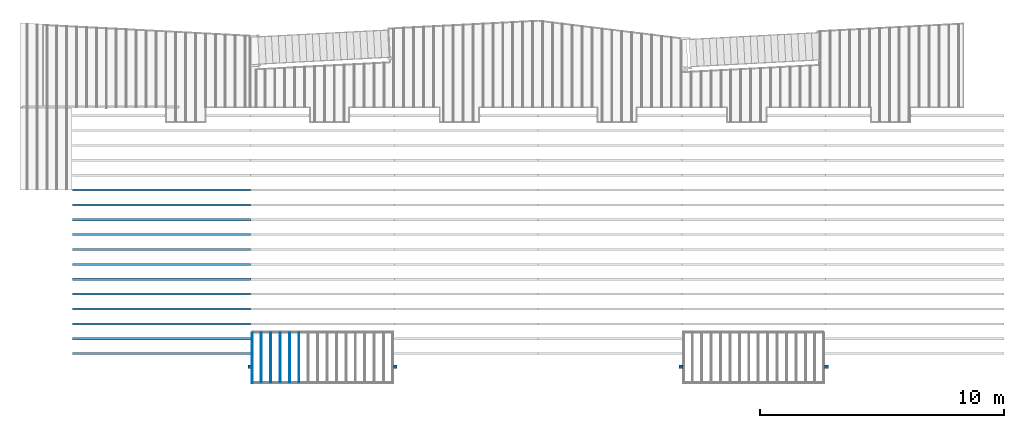
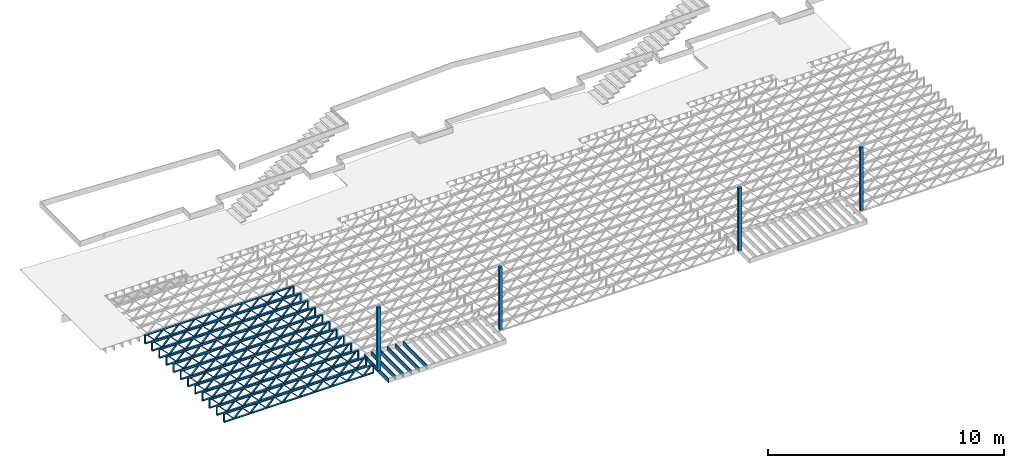
# One storey, part 1 of 23: 18 beams, 4 columns, 2 elements without a shape of their own.
"""IFC4 building model written with IfcOpenShell, lengths in feet."""

from ifc_helpers import new_model, entity, si_unit, converted_unit, derived_unit, direction, frame, frame_2d, origin, origin_2d_with_axis, place, context, subcontext, project, spatial, rectangle, extrude, source, transform, mapped, material, material_profile, profile_set, profile_usage, type_object, type_shapes, element, aggregate, save


model = new_model("IFC4")

# Units and contexts
model_context_1 = context("Model", 3, precision=0.0001, world=origin(), true_north=direction((6.12303176911189e-17, 1.0)))
model_context_2 = context("Model", 3, precision=0.0001, world=origin(), true_north=direction((6.12303176911189e-17, 1.0)))
body_context = subcontext(model_context_2, "Body", "Model", "MODEL_VIEW")
ifc_project = project(units=[converted_unit("LENGTHUNIT", "FOOT", entity("IfcRatioMeasure", 0.3048), si_unit("LENGTHUNIT", "METRE"), dimensions=[1, 0, 0, 0, 0, 0, 0]), converted_unit("AREAUNIT", "SQUARE FOOT", entity("IfcRatioMeasure", 0.09290304), si_unit("AREAUNIT", "SQUARE_METRE"), dimensions=[2, 0, 0, 0, 0, 0, 0]), converted_unit("VOLUMEUNIT", "CUBIC FOOT", entity("IfcRatioMeasure", 0.028316846592), si_unit("VOLUMEUNIT", "CUBIC_METRE"), dimensions=[3, 0, 0, 0, 0, 0, 0]), converted_unit("PLANEANGLEUNIT", "DEGREE", entity("IfcRatioMeasure", 0.0174532925199433), si_unit("PLANEANGLEUNIT", "RADIAN"), dimensions=[0, 0, 0, 0, 0, 0, 0]), si_unit("MASSUNIT", "GRAM", prefix="KILO"), derived_unit("MASSDENSITYUNIT", [(si_unit("MASSUNIT", "GRAM", prefix="KILO"), 1), (si_unit("LENGTHUNIT", "METRE"), -3)]), derived_unit("MOMENTOFINERTIAUNIT", [(si_unit("LENGTHUNIT", "METRE"), 4)]), si_unit("TIMEUNIT", "SECOND"), si_unit("FREQUENCYUNIT", "HERTZ"), si_unit("THERMODYNAMICTEMPERATUREUNIT", "DEGREE_CELSIUS"), derived_unit("THERMALTRANSMITTANCEUNIT", [(si_unit("MASSUNIT", "GRAM", prefix="KILO"), 1), (si_unit("THERMODYNAMICTEMPERATUREUNIT", "KELVIN"), -1), (si_unit("TIMEUNIT", "SECOND"), -3)]), derived_unit("VOLUMETRICFLOWRATEUNIT", [(si_unit("LENGTHUNIT", "METRE"), 3), (si_unit("TIMEUNIT", "SECOND"), -1)]), si_unit("ELECTRICCURRENTUNIT", "AMPERE"), si_unit("ELECTRICVOLTAGEUNIT", "VOLT"), si_unit("POWERUNIT", "WATT"), si_unit("FORCEUNIT", "NEWTON"), si_unit("ILLUMINANCEUNIT", "LUX"), si_unit("LUMINOUSFLUXUNIT", "LUMEN"), si_unit("LUMINOUSINTENSITYUNIT", "CANDELA"), derived_unit("USERDEFINED", [(si_unit("MASSUNIT", "GRAM", prefix="KILO"), -1), (si_unit("LENGTHUNIT", "METRE"), -2), (si_unit("TIMEUNIT", "SECOND"), 3), (si_unit("LUMINOUSFLUXUNIT", "LUMEN"), 1)]), derived_unit("LINEARVELOCITYUNIT", [(si_unit("LENGTHUNIT", "METRE"), 1), (si_unit("TIMEUNIT", "SECOND"), -1)]), si_unit("PRESSUREUNIT", "PASCAL"), derived_unit("USERDEFINED", [(si_unit("LENGTHUNIT", "METRE"), -2), (si_unit("MASSUNIT", "GRAM", prefix="KILO"), 1), (si_unit("TIMEUNIT", "SECOND"), -2)]), derived_unit("LINEARFORCEUNIT", [(si_unit("MASSUNIT", "GRAM", prefix="KILO"), 1), (si_unit("LENGTHUNIT", "METRE"), 1), (si_unit("TIMEUNIT", "SECOND"), -2), (si_unit("LENGTHUNIT", "METRE"), -1)]), derived_unit("PLANARFORCEUNIT", [(si_unit("MASSUNIT", "GRAM", prefix="KILO"), 1), (si_unit("LENGTHUNIT", "METRE"), 1), (si_unit("TIMEUNIT", "SECOND"), -2), (si_unit("LENGTHUNIT", "METRE"), -2)])], contexts=[model_context_1])

# Site, building, storey
site_placement = place(None, origin())
site = spatial("IfcSite", under=ifc_project, at=site_placement, CompositionType="ELEMENT")
building_placement = place(site_placement, origin())
building = spatial("IfcBuilding", under=site, at=building_placement, CompositionType="ELEMENT")
storey_placement = place(building_placement, frame((0.0, 0.0, 10.8020833333333)))
storey = spatial("IfcBuildingStorey", under=building, at=storey_placement, Name="2ND FLOOR", CompositionType="ELEMENT", Elevation=10.8020833333333)

# Columns
ifc_material_1 = material(Name="STRUCTURAL WOOD COLUMN - SIZE TBD", Category="Materials")
ifc_material_profile_1 = material_profile(ifc_material_1, rectangle(XDim=0.458333333333333, YDim=0.5, at=frame_2d((0.0, -2.77555756156289e-17), x_axis=(1.0, 0.0))), Name="(4) 2X6 - BUILT-UP COLUMN")
ifc_profile_set_1 = profile_set([ifc_material_profile_1], Name="(4) 2X6 - BUILT-UP COLUMN")
ifc_profile_usage_1 = profile_usage(ifc_profile_set_1)
column_type = type_object("IfcColumnType", Name="Timber-Column:(4) 2X6 - BUILT-UP COLUMN", PredefinedType="COLUMN", material=ifc_profile_set_1)
shared_shape_1 = source(origin(), body_context, "Body", "SweptSolid", [
    extrude(rectangle(XDim=0.458333333333333, YDim=0.5, at=frame_2d((0.0, -2.77555756156289e-17), x_axis=(1.0, 0.0))), frame((0.0, 0.0, 10.8020833333333), z_axis=(0.0, 0.0, 1.0), x_axis=(0.0, -1.0, 0.0)), (0.0, 0.0, 1.0), 10.6666666666667),
])
type_shapes(column_type, [shared_shape_1])
column_1_placement = place(storey_placement, frame((-183.863160485529, 924.091101549317, -10.8020833333333)))
element("IfcColumn", 1, at=column_1_placement, inside=storey, type_object=column_type, material=ifc_profile_usage_1, Name="Timber-Column:(4) 2X6 - BUILT-UP COLUMN", ObjectType="Timber-Column:(4) 2X6 - BUILT-UP COLUMN", PredefinedType="COLUMN", context=body_context, shape_type="MappedRepresentation", body=[
    mapped(shared_shape_1, transform((0.0, 0.0, 0.0), scale=1.0)),
])
ifc_profile_usage_2 = profile_usage(ifc_profile_set_1)
column_2_placement = place(storey_placement, frame((-222.279828726425, 924.091101549317, -10.8020833333333)))
element("IfcColumn", 2, at=column_2_placement, inside=storey, type_object=column_type, material=ifc_profile_usage_2, Name="Timber-Column:(4) 2X6 - BUILT-UP COLUMN", ObjectType="Timber-Column:(4) 2X6 - BUILT-UP COLUMN", PredefinedType="COLUMN", context=body_context, shape_type="MappedRepresentation", body=[
    mapped(shared_shape_1, transform((0.0, 0.0, 0.0), scale=1.0)),
])
ifc_profile_usage_3 = profile_usage(ifc_profile_set_1)
column_3_placement = place(storey_placement, frame((-241.863160485529, 924.091101549317, -10.8020833333333)))
element("IfcColumn", 3, at=column_3_placement, inside=storey, type_object=column_type, material=ifc_profile_usage_3, Name="Timber-Column:(4) 2X6 - BUILT-UP COLUMN", ObjectType="Timber-Column:(4) 2X6 - BUILT-UP COLUMN", PredefinedType="COLUMN", context=body_context, shape_type="MappedRepresentation", body=[
    mapped(shared_shape_1, transform((0.0, 0.0, 0.0), scale=1.0)),
])
ifc_profile_usage_4 = profile_usage(ifc_profile_set_1)
column_4_placement = place(storey_placement, frame((-164.279827152195, 924.091101549317, -10.8020833333333)))
element("IfcColumn", 4, at=column_4_placement, inside=storey, type_object=column_type, material=ifc_profile_usage_4, Name="Timber-Column:(4) 2X6 - BUILT-UP COLUMN", ObjectType="Timber-Column:(4) 2X6 - BUILT-UP COLUMN", PredefinedType="COLUMN", context=body_context, shape_type="MappedRepresentation", body=[
    mapped(shared_shape_1, transform((0.0, 0.0, 0.0), scale=1.0)),
])

# Assembly, beams
assembly_1_placement = place(storey_placement, origin())
assembly_1 = element("IfcElementAssembly", 5, at=assembly_1_placement, inside=storey, Name="Structural Beam System:Structural Framing System", ObjectType="Structural Beam System:Structural Framing System", AssemblyPlace="NOTDEFINED", PredefinedType="BEAM_GRID")
ifc_material_2 = material(Name="WOOD TRUSS", Category="Materials")
ifc_material_profile_2 = material_profile(ifc_material_2, rectangle(XDim=1.73473973950632, YDim=0.125, at=frame_2d((-1.11022302462516e-16, 8.32667268468867e-17), x_axis=(1.0, 0.0))))
ifc_material_profile_3 = material_profile(ifc_material_2, rectangle(XDim=1.73473973950633, YDim=0.125, at=frame_2d((-1.11022302462516e-16, 8.32667268468867e-17), x_axis=(1.0, 0.0))))
ifc_material_profile_4 = material_profile(ifc_material_2, rectangle(XDim=1.73473973950632, YDim=0.125, at=frame_2d((-5.55111512312578e-17, 1.38777878078145e-16), x_axis=(1.0, 0.0))))
ifc_material_profile_5 = material_profile(ifc_material_2, rectangle(XDim=1.73473973950633, YDim=0.125, at=frame_2d((-1.11022302462516e-16, 8.32667268468867e-17), x_axis=(1.0, 0.0))))
ifc_material_profile_6 = material_profile(ifc_material_2, rectangle(XDim=1.73473973950632, YDim=0.125, at=frame_2d((-1.11022302462516e-16, 8.32667268468867e-17), x_axis=(1.0, 0.0))))
ifc_material_profile_7 = material_profile(ifc_material_2, rectangle(XDim=1.73473973950633, YDim=0.125, at=frame_2d((-2.77555756156289e-16, 3.05311331771918e-16), x_axis=(1.0, 0.0))))
ifc_material_profile_8 = material_profile(ifc_material_2, rectangle(XDim=1.73473973950632, YDim=0.124999999999999, at=frame_2d((-3.88578058618805e-16, -2.4980018054066e-16), x_axis=(1.0, 0.0))))
ifc_material_profile_9 = material_profile(ifc_material_2, rectangle(XDim=1.73473973950633, YDim=0.125, at=frame_2d((2.77555756156289e-16, -3.05311331771918e-16), x_axis=(1.0, 0.0))))
ifc_material_profile_10 = material_profile(ifc_material_2, rectangle(XDim=1.73473973950632, YDim=0.124999999999999, at=frame_2d((-1.11022302462516e-16, 8.32667268468867e-17), x_axis=(1.0, 0.0))))
ifc_material_profile_11 = material_profile(ifc_material_2, rectangle(XDim=1.73473973950633, YDim=0.125, at=origin_2d_with_axis()))
ifc_material_profile_12 = material_profile(ifc_material_2, rectangle(XDim=0.124999999999982, YDim=0.291666666666668, at=origin_2d_with_axis()))
ifc_material_profile_13 = material_profile(ifc_material_2, rectangle(XDim=0.124999999999932, YDim=0.291666666666664, at=origin_2d_with_axis()))
ifc_material_profile_14 = material_profile(ifc_material_2, rectangle(XDim=1.25000000000002, YDim=0.29166666666667, at=origin_2d_with_axis()))
ifc_material_profile_15 = material_profile(ifc_material_2, rectangle(XDim=1.25000000000004, YDim=0.291666666666667, at=origin_2d_with_axis()))
ifc_profile_set_2 = profile_set([ifc_material_profile_2, ifc_material_profile_3, ifc_material_profile_4, ifc_material_profile_5, ifc_material_profile_6, ifc_material_profile_7, ifc_material_profile_8, ifc_material_profile_9, ifc_material_profile_10, ifc_material_profile_11, ifc_material_profile_12, ifc_material_profile_13, ifc_material_profile_14, ifc_material_profile_15])
ifc_profile_usage_5 = profile_usage(ifc_profile_set_2, cardinal=8)
beam_type_1 = type_object("IfcBeamType", PredefinedType="BEAM", material=ifc_profile_set_2)
shared_shape_2 = source(origin(), body_context, "Body", "SweptSolid", [
    extrude(rectangle(XDim=1.73473973950632, YDim=0.124999999999999, at=frame_2d((5.55111512312578e-16, 7.21644966006352e-16), x_axis=(1.0, 0.0))), frame((8.42202085580899, -0.145833333333334, 0.0), z_axis=(0.0, 1.0, 0.0), x_axis=(0.693383046997606, 0.0, 0.720569184836762)), (0.0, 0.0, 1.0), 0.291666666666667),
    extrude(rectangle(XDim=1.73473973950633, YDim=0.125, at=origin_2d_with_axis()), frame((7.17173498213572, -0.145833333333334, 0.0), z_axis=(0.0, 1.0, 0.0), x_axis=(0.69338304699761, 0.0, -0.720569184836758)), (0.0, 0.0, 1.0), 0.291666666666666),
    extrude(rectangle(XDim=1.73473973950632, YDim=0.124999999999999, at=frame_2d((-1.11022302462516e-16, 8.32667268468867e-17), x_axis=(1.0, 0.0))), frame((5.82306154948498, -0.145833333333334, 0.0), z_axis=(0.0, 1.0, 0.0), x_axis=(0.693383046997606, 0.0, 0.720569184836762)), (0.0, 0.0, 1.0), 0.291666666666667),
    extrude(rectangle(XDim=1.73473973950633, YDim=0.125, at=origin_2d_with_axis()), frame((4.57277567581171, -0.145833333333334, 0.0), z_axis=(0.0, 1.0, 0.0), x_axis=(0.69338304699761, 0.0, -0.720569184836758)), (0.0, 0.0, 1.0), 0.291666666666666),
    extrude(rectangle(XDim=1.73473973950632, YDim=0.125, at=frame_2d((2.22044604925031e-16, 3.88578058618805e-16), x_axis=(1.0, 0.0))), frame((3.22410224316097, -0.145833333333334, 0.0), z_axis=(0.0, 1.0, 0.0), x_axis=(0.693383046997606, 0.0, 0.720569184836762)), (0.0, 0.0, 1.0), 0.291666666666667),
    extrude(rectangle(XDim=1.73473973950633, YDim=0.125, at=frame_2d((-1.11022302462516e-16, 8.32667268468867e-17), x_axis=(1.0, 0.0))), frame((1.9738163694877, -0.145833333333334, 0.0), z_axis=(0.0, 1.0, 0.0), x_axis=(0.69338304699761, 0.0, -0.720569184836758)), (0.0, 0.0, 1.0), 0.291666666666667),
    extrude(rectangle(XDim=1.73473973950632, YDim=0.125, at=frame_2d((-5.55111512312578e-17, 1.38777878078145e-16), x_axis=(1.0, 0.0))), frame((0.625142936836964, -0.145833333333334, 0.0), z_axis=(0.0, 1.0, 0.0), x_axis=(0.693383046997606, 0.0, 0.720569184836762)), (0.0, 0.0, 1.0), 0.291666666666667),
    extrude(rectangle(XDim=1.73473973950633, YDim=0.125, at=frame_2d((-1.11022302462516e-16, 8.32667268468867e-17), x_axis=(1.0, 0.0))), frame((-0.625142936836306, -0.145833333333334, 0.0), z_axis=(0.0, 1.0, 0.0), x_axis=(0.69338304699761, 0.0, -0.720569184836758)), (0.0, 0.0, 1.0), 0.291666666666667),
    extrude(rectangle(XDim=1.73473973950632, YDim=0.125, at=frame_2d((-1.11022302462516e-16, 8.32667268468867e-17), x_axis=(1.0, 0.0))), frame((-1.97381636948704, -0.145833333333334, 0.0), z_axis=(0.0, 1.0, 0.0), x_axis=(0.693383046997606, 0.0, 0.720569184836762)), (0.0, 0.0, 1.0), 0.291666666666667),
    extrude(rectangle(XDim=1.73473973950633, YDim=0.125, at=origin_2d_with_axis()), frame((-3.22410224316031, -0.145833333333334, 0.0), z_axis=(0.0, 1.0, 0.0), x_axis=(0.69338304699761, 0.0, -0.720569184836758)), (0.0, 0.0, 1.0), 0.291666666666667),
    extrude(rectangle(XDim=1.73473973950632, YDim=0.124999999999999, at=frame_2d((-1.11022302462516e-16, 8.32667268468867e-17), x_axis=(1.0, 0.0))), frame((-4.57277567581105, -0.145833333333334, 0.0), z_axis=(0.0, 1.0, 0.0), x_axis=(0.693383046997606, 0.0, 0.720569184836762)), (0.0, 0.0, 1.0), 0.291666666666667),
    extrude(rectangle(XDim=1.73473973950633, YDim=0.125, at=origin_2d_with_axis()), frame((-5.82306154948432, -0.145833333333334, 0.0), z_axis=(0.0, 1.0, 0.0), x_axis=(0.69338304699761, 0.0, -0.720569184836758)), (0.0, 0.0, 1.0), 0.291666666666666),
    extrude(rectangle(XDim=1.73473973950632, YDim=0.124999999999999, at=frame_2d((-1.11022302462516e-16, 8.32667268468867e-17), x_axis=(1.0, 0.0))), frame((-7.17173498213506, -0.145833333333334, 0.0), z_axis=(0.0, 1.0, 0.0), x_axis=(0.693383046997606, 0.0, 0.720569184836762)), (0.0, 0.0, 1.0), 0.291666666666667),
    extrude(rectangle(XDim=1.73473973950633, YDim=0.125, at=frame_2d((-2.77555756156289e-16, 3.05311331771918e-16), x_axis=(1.0, 0.0))), frame((-8.42202085580833, -0.145833333333334, 0.0), z_axis=(0.0, 1.0, 0.0), x_axis=(0.69338304699761, 0.0, -0.720569184836758)), (0.0, 0.0, 1.0), 0.291666666666666),
    extrude(rectangle(XDim=1.73473973950632, YDim=0.125, at=frame_2d((-7.21644966006352e-16, -5.55111512312578e-16), x_axis=(1.0, 0.0))), frame((11.020980162133, -0.145833333333334, 0.0), z_axis=(0.0, 1.0, 0.0), x_axis=(0.693383046997606, 0.0, 0.720569184836762)), (0.0, 0.0, 1.0), 0.291666666666667),
    extrude(rectangle(XDim=1.73473973950633, YDim=0.125, at=origin_2d_with_axis()), frame((9.77069428845972, -0.145833333333334, 0.0), z_axis=(0.0, 1.0, 0.0), x_axis=(0.69338304699761, 0.0, -0.720569184836758)), (0.0, 0.0, 1.0), 0.291666666666666),
    extrude(rectangle(XDim=1.73473973950632, YDim=0.125, at=frame_2d((-5.55111512312578e-17, 8.32667268468867e-17), x_axis=(1.0, 0.0))), frame((-9.77069428845906, -0.145833333333334, 0.0), z_axis=(0.0, 1.0, 0.0), x_axis=(0.693383046997606, 0.0, 0.720569184836762)), (0.0, 0.0, 1.0), 0.291666666666667),
    extrude(rectangle(XDim=1.73473973950633, YDim=0.125, at=origin_2d_with_axis()), frame((-11.0209801621323, -0.145833333333334, 0.0), z_axis=(0.0, 1.0, 0.0), x_axis=(0.69338304699761, 0.0, -0.720569184836758)), (0.0, 0.0, 1.0), 0.291666666666666),
    extrude(rectangle(XDim=0.124999999999982, YDim=0.291666666666668, at=origin_2d_with_axis()), frame((-12.0625038919626, 0.0, 0.687500000000054), z_axis=(1.0, 0.0, 0.0), x_axis=(0.0, 0.0, -1.0)), (0.0, 0.0, 1.0), 24.1250077839252),
    extrude(rectangle(XDim=0.124999999999932, YDim=0.291666666666664, at=origin_2d_with_axis()), frame((-12.0625038919624, 0.0, -0.687499999999984), z_axis=(1.0, 0.0, 0.0), x_axis=(0.0, 0.0, -1.0)), (0.0, 0.0, 1.0), 24.125007783925),
    extrude(rectangle(XDim=1.25000000000002, YDim=0.29166666666667, at=origin_2d_with_axis()), frame((11.9375038919626, 0.0, 0.0), z_axis=(1.0, 0.0, 0.0), x_axis=(0.0, 0.0, -1.0)), (0.0, 0.0, 1.0), 0.12500000000002),
    extrude(rectangle(XDim=1.25000000000004, YDim=0.291666666666667, at=origin_2d_with_axis()), frame((-12.0625038919626, 0.0, 0.0), z_axis=(1.0, 0.0, 0.0), x_axis=(0.0, 0.0, -1.0)), (0.0, 0.0, 1.0), 0.125000000000023),
])
type_shapes(beam_type_1, [shared_shape_2])
beam_1_placement = place(assembly_1_placement, frame((-253.675664405631, 927.861934882651, -0.947916666657859)))
beam_1 = element("IfcBeam", 6, at=beam_1_placement, type_object=beam_type_1, material=ifc_profile_usage_5, PredefinedType="BEAM", context=body_context, shape_type="MappedRepresentation", body=[
    mapped(shared_shape_2, transform((0.0, 0.0, 0.0), scale=1.0)),
])
ifc_profile_usage_6 = profile_usage(ifc_profile_set_2, cardinal=8)
beam_2_placement = place(assembly_1_placement, frame((-253.675664405631, 925.861934882651, -0.947916666657859)))
beam_2 = element("IfcBeam", 7, at=beam_2_placement, type_object=beam_type_1, material=ifc_profile_usage_6, PredefinedType="BEAM", context=body_context, shape_type="MappedRepresentation", body=[
    mapped(shared_shape_2, transform((0.0, 0.0, 0.0), scale=1.0)),
])

assembly_2_placement = place(storey_placement, origin())
assembly_2 = element("IfcElementAssembly", 8, at=assembly_2_placement, inside=storey, Name="Structural Beam System:Structural Framing System", ObjectType="Structural Beam System:Structural Framing System", AssemblyPlace="NOTDEFINED", PredefinedType="BEAM_GRID")
ifc_material_3 = material(Category="Materials")
ifc_material_profile_16 = material_profile(ifc_material_3, rectangle(XDim=0.770833333333333, YDim=0.124999999999994, at=frame_2d((-5.55111512312578e-17, 0.0), x_axis=(1.0, 0.0))))
ifc_profile_set_3 = profile_set([ifc_material_profile_16])
ifc_profile_usage_7 = profile_usage(ifc_profile_set_3, cardinal=8)
beam_type_2 = type_object("IfcBeamType", PredefinedType="BEAM", material=ifc_profile_set_3)
shared_shape_3 = source(origin(), body_context, "Body", "SweptSolid", [
    extrude(rectangle(XDim=0.770833333333333, YDim=0.124999999999994, at=frame_2d((-5.55111512312578e-17, 0.0), x_axis=(1.0, 0.0))), frame((-3.35416666666737, 0.0, 0.0), z_axis=(1.0, 0.0, 0.0), x_axis=(0.0, 0.0, -1.0)), (0.0, 0.0, 1.0), 6.70833333333462),
])
type_shapes(beam_type_2, [shared_shape_3])
beam_3_placement = place(assembly_2_placement, frame((-240.307864615095, 925.341101549316, -0.645833333333471), z_axis=(0.0, 0.0, 1.0), x_axis=(0.0, 1.0, 0.0)))
beam_3 = element("IfcBeam", 9, at=beam_3_placement, type_object=beam_type_2, material=ifc_profile_usage_7, PredefinedType="BEAM", context=body_context, shape_type="MappedRepresentation", body=[
    mapped(shared_shape_3, transform((0.0, 0.0, 0.0), scale=1.0)),
])
ifc_profile_usage_8 = profile_usage(ifc_profile_set_3, cardinal=8)
beam_4_placement = place(assembly_2_placement, frame((-239.040980934537, 925.341101549316, -0.645833333333471), z_axis=(0.0, 0.0, 1.0), x_axis=(0.0, 1.0, 0.0)))
beam_4 = element("IfcBeam", 10, at=beam_4_placement, type_object=beam_type_2, material=ifc_profile_usage_8, PredefinedType="BEAM", context=body_context, shape_type="MappedRepresentation", body=[
    mapped(shared_shape_3, transform((0.0, 0.0, 0.0), scale=1.0)),
])
ifc_profile_usage_9 = profile_usage(ifc_profile_set_3, cardinal=8)
beam_5_placement = place(assembly_2_placement, frame((-237.774097253978, 925.341101549316, -0.645833333333471), z_axis=(0.0, 0.0, 1.0), x_axis=(0.0, 1.0, 0.0)))
beam_5 = element("IfcBeam", 11, at=beam_5_placement, type_object=beam_type_2, material=ifc_profile_usage_9, PredefinedType="BEAM", context=body_context, shape_type="MappedRepresentation", body=[
    mapped(shared_shape_3, transform((0.0, 0.0, 0.0), scale=1.0)),
])
ifc_profile_usage_10 = profile_usage(ifc_profile_set_3, cardinal=8)
beam_6_placement = place(assembly_2_placement, frame((-236.50721357342, 925.341101549317, -0.645833333333471), z_axis=(0.0, 0.0, 1.0), x_axis=(0.0, 1.0, 0.0)))
beam_6 = element("IfcBeam", 12, at=beam_6_placement, type_object=beam_type_2, material=ifc_profile_usage_10, PredefinedType="BEAM", context=body_context, shape_type="MappedRepresentation", body=[
    mapped(shared_shape_3, transform((0.0, 0.0, 0.0), scale=1.0)),
])
ifc_profile_usage_11 = profile_usage(ifc_profile_set_3, cardinal=8)
beam_7_placement = place(assembly_2_placement, frame((-235.240329892862, 925.341101549317, -0.645833333333471), z_axis=(0.0, 0.0, 1.0), x_axis=(0.0, 1.0, 0.0)))
beam_7 = element("IfcBeam", 13, at=beam_7_placement, type_object=beam_type_2, material=ifc_profile_usage_11, PredefinedType="BEAM", context=body_context, shape_type="MappedRepresentation", body=[
    mapped(shared_shape_3, transform((0.0, 0.0, 0.0), scale=1.0)),
])
aggregate(assembly_2, [beam_3, beam_4, beam_5, beam_6, beam_7])

# Beam
ifc_profile_usage_12 = profile_usage(ifc_profile_set_3, cardinal=8)
beam_type_3 = type_object("IfcBeamType", PredefinedType="BEAM", material=ifc_profile_set_3)
shared_shape_4 = source(origin(), body_context, "Body", "SweptSolid", [
    extrude(rectangle(XDim=0.770833333333333, YDim=0.124999999999994, at=origin_2d_with_axis()), frame((-3.47916666666737, 0.0, 0.0), z_axis=(1.0, 0.0, 0.0), x_axis=(0.0, 0.0, -1.0)), (0.0, 0.0, 1.0), 6.83333333333471),
])
type_shapes(beam_type_3, [shared_shape_4])
beam_8_placement = place(storey_placement, frame((-241.508993818863, 925.341101549316, -0.645833333332796), z_axis=(0.0, 0.0, 1.0), x_axis=(0.0, 1.0, 0.0)))
element("IfcBeam", 14, at=beam_8_placement, inside=storey, type_object=beam_type_3, material=ifc_profile_usage_12, PredefinedType="BEAM", context=body_context, shape_type="MappedRepresentation", body=[
    mapped(shared_shape_4, transform((0.0, 0.0, 0.0), scale=1.0)),
])

ifc_profile_usage_13 = profile_usage(ifc_profile_set_2, cardinal=8)
beam_type_4 = type_object("IfcBeamType", PredefinedType="BEAM", material=ifc_profile_set_2)
shared_shape_5 = source(origin(), body_context, "Body", "SweptSolid", [
    extrude(rectangle(XDim=1.73473973950632, YDim=0.124999999999999, at=frame_2d((5.55111512312578e-16, 7.21644966006352e-16), x_axis=(1.0, 0.0))), frame((8.37514585578398, -0.145833333333334, 0.0), z_axis=(0.0, 1.0, 0.0), x_axis=(0.693383046997606, 0.0, 0.720569184836762)), (0.0, 0.0, 1.0), 0.291666666666667),
    extrude(rectangle(XDim=1.73473973950633, YDim=0.125, at=origin_2d_with_axis()), frame((7.12485998211071, -0.145833333333334, 0.0), z_axis=(0.0, 1.0, 0.0), x_axis=(0.69338304699761, 0.0, -0.720569184836758)), (0.0, 0.0, 1.0), 0.291666666666666),
    extrude(rectangle(XDim=1.73473973950632, YDim=0.124999999999999, at=frame_2d((-1.11022302462516e-16, 8.32667268468867e-17), x_axis=(1.0, 0.0))), frame((5.79181154946831, -0.145833333333334, 0.0), z_axis=(0.0, 1.0, 0.0), x_axis=(0.693383046997606, 0.0, 0.720569184836762)), (0.0, 0.0, 1.0), 0.291666666666667),
    extrude(rectangle(XDim=1.73473973950633, YDim=0.125, at=origin_2d_with_axis()), frame((4.54152567579504, -0.145833333333334, 0.0), z_axis=(0.0, 1.0, 0.0), x_axis=(0.69338304699761, 0.0, -0.720569184836758)), (0.0, 0.0, 1.0), 0.291666666666666),
    extrude(rectangle(XDim=1.73473973950632, YDim=0.125, at=frame_2d((2.22044604925031e-16, 3.88578058618805e-16), x_axis=(1.0, 0.0))), frame((3.20847724315264, -0.145833333333334, 0.0), z_axis=(0.0, 1.0, 0.0), x_axis=(0.693383046997606, 0.0, 0.720569184836762)), (0.0, 0.0, 1.0), 0.291666666666667),
    extrude(rectangle(XDim=1.73473973950633, YDim=0.125, at=frame_2d((-1.11022302462516e-16, 8.32667268468867e-17), x_axis=(1.0, 0.0))), frame((1.95819136947937, -0.145833333333334, 0.0), z_axis=(0.0, 1.0, 0.0), x_axis=(0.69338304699761, 0.0, -0.720569184836758)), (0.0, 0.0, 1.0), 0.291666666666667),
    extrude(rectangle(XDim=1.73473973950632, YDim=0.125, at=frame_2d((-5.55111512312578e-17, 1.38777878078145e-16), x_axis=(1.0, 0.0))), frame((0.625142936836964, -0.145833333333334, 0.0), z_axis=(0.0, 1.0, 0.0), x_axis=(0.693383046997606, 0.0, 0.720569184836762)), (0.0, 0.0, 1.0), 0.291666666666667),
    extrude(rectangle(XDim=1.73473973950633, YDim=0.125, at=frame_2d((-1.11022302462516e-16, 8.32667268468867e-17), x_axis=(1.0, 0.0))), frame((-0.625142936836306, -0.145833333333334, 0.0), z_axis=(0.0, 1.0, 0.0), x_axis=(0.69338304699761, 0.0, -0.720569184836758)), (0.0, 0.0, 1.0), 0.291666666666667),
    extrude(rectangle(XDim=1.73473973950632, YDim=0.125, at=frame_2d((-1.11022302462516e-16, 8.32667268468867e-17), x_axis=(1.0, 0.0))), frame((-1.95819136947871, -0.145833333333334, 0.0), z_axis=(0.0, 1.0, 0.0), x_axis=(0.693383046997606, 0.0, 0.720569184836762)), (0.0, 0.0, 1.0), 0.291666666666667),
    extrude(rectangle(XDim=1.73473973950633, YDim=0.125, at=origin_2d_with_axis()), frame((-3.20847724315198, -0.145833333333334, 0.0), z_axis=(0.0, 1.0, 0.0), x_axis=(0.69338304699761, 0.0, -0.720569184836758)), (0.0, 0.0, 1.0), 0.291666666666667),
    extrude(rectangle(XDim=1.73473973950632, YDim=0.124999999999999, at=frame_2d((-1.11022302462516e-16, 8.32667268468867e-17), x_axis=(1.0, 0.0))), frame((-4.54152567579438, -0.145833333333334, 0.0), z_axis=(0.0, 1.0, 0.0), x_axis=(0.693383046997606, 0.0, 0.720569184836762)), (0.0, 0.0, 1.0), 0.291666666666667),
    extrude(rectangle(XDim=1.73473973950633, YDim=0.125, at=origin_2d_with_axis()), frame((-5.79181154946765, -0.145833333333334, 0.0), z_axis=(0.0, 1.0, 0.0), x_axis=(0.69338304699761, 0.0, -0.720569184836758)), (0.0, 0.0, 1.0), 0.291666666666666),
    extrude(rectangle(XDim=1.73473973950632, YDim=0.124999999999999, at=frame_2d((-1.11022302462516e-16, 8.32667268468867e-17), x_axis=(1.0, 0.0))), frame((-7.12485998211005, -0.145833333333334, 0.0), z_axis=(0.0, 1.0, 0.0), x_axis=(0.693383046997606, 0.0, 0.720569184836762)), (0.0, 0.0, 1.0), 0.291666666666667),
    extrude(rectangle(XDim=1.73473973950633, YDim=0.125, at=frame_2d((-2.77555756156289e-16, 3.05311331771918e-16), x_axis=(1.0, 0.0))), frame((-8.37514585578332, -0.145833333333334, 0.0), z_axis=(0.0, 1.0, 0.0), x_axis=(0.69338304699761, 0.0, -0.720569184836758)), (0.0, 0.0, 1.0), 0.291666666666666),
    extrude(rectangle(XDim=1.73473973950632, YDim=0.125, at=frame_2d((-7.21644966006352e-16, -5.55111512312578e-16), x_axis=(1.0, 0.0))), frame((10.9584801620997, -0.145833333333334, 0.0), z_axis=(0.0, 1.0, 0.0), x_axis=(0.693383046997606, 0.0, 0.720569184836762)), (0.0, 0.0, 1.0), 0.291666666666667),
    extrude(rectangle(XDim=1.73473973950633, YDim=0.125, at=origin_2d_with_axis()), frame((9.70819428842638, -0.145833333333334, 0.0), z_axis=(0.0, 1.0, 0.0), x_axis=(0.69338304699761, 0.0, -0.720569184836758)), (0.0, 0.0, 1.0), 0.291666666666666),
    extrude(rectangle(XDim=1.73473973950632, YDim=0.125, at=frame_2d((-5.55111512312578e-17, 8.32667268468867e-17), x_axis=(1.0, 0.0))), frame((-9.70819428842572, -0.145833333333334, 0.0), z_axis=(0.0, 1.0, 0.0), x_axis=(0.693383046997606, 0.0, 0.720569184836762)), (0.0, 0.0, 1.0), 0.291666666666667),
    extrude(rectangle(XDim=1.73473973950633, YDim=0.125, at=origin_2d_with_axis()), frame((-10.958480162099, -0.145833333333334, 0.0), z_axis=(0.0, 1.0, 0.0), x_axis=(0.69338304699761, 0.0, -0.720569184836758)), (0.0, 0.0, 1.0), 0.291666666666666),
    extrude(rectangle(XDim=0.124999999999982, YDim=0.291666666666668, at=origin_2d_with_axis()), frame((-12.0000038919293, 0.0, 0.687500000000054), z_axis=(1.0, 0.0, 0.0), x_axis=(0.0, 0.0, -1.0)), (0.0, 0.0, 1.0), 24.0000077838585),
    extrude(rectangle(XDim=0.124999999999932, YDim=0.291666666666664, at=origin_2d_with_axis()), frame((-12.0000038919291, 0.0, -0.687499999999984), z_axis=(1.0, 0.0, 0.0), x_axis=(0.0, 0.0, -1.0)), (0.0, 0.0, 1.0), 24.0000077838583),
    extrude(rectangle(XDim=1.25000000000002, YDim=0.29166666666667, at=origin_2d_with_axis()), frame((11.8750038919292, 0.0, 0.0), z_axis=(1.0, 0.0, 0.0), x_axis=(0.0, 0.0, -1.0)), (0.0, 0.0, 1.0), 0.12500000000002),
    extrude(rectangle(XDim=1.25000000000004, YDim=0.291666666666667, at=origin_2d_with_axis()), frame((-12.0000038919293, 0.0, 0.0), z_axis=(1.0, 0.0, 0.0), x_axis=(0.0, 0.0, -1.0)), (0.0, 0.0, 1.0), 0.125000000000023),
])
type_shapes(beam_type_4, [shared_shape_5])
beam_9_placement = place(assembly_1_placement, frame((-253.738164405664, 933.861934882651, -0.947916666657859)))
beam_9 = element("IfcBeam", 15, at=beam_9_placement, type_object=beam_type_4, material=ifc_profile_usage_13, PredefinedType="BEAM", context=body_context, shape_type="MappedRepresentation", body=[
    mapped(shared_shape_5, transform((0.0, 0.0, 0.0), scale=1.0)),
])

ifc_profile_usage_14 = profile_usage(ifc_profile_set_2, cardinal=8)
beam_10_placement = place(assembly_1_placement, frame((-253.738164405664, 939.861934882651, -0.947916666657859)))
beam_10 = element("IfcBeam", 16, at=beam_10_placement, type_object=beam_type_4, material=ifc_profile_usage_14, PredefinedType="BEAM", context=body_context, shape_type="MappedRepresentation", body=[
    mapped(shared_shape_5, transform((0.0, 0.0, 0.0), scale=1.0)),
])

ifc_profile_usage_15 = profile_usage(ifc_profile_set_2, cardinal=8)
beam_11_placement = place(assembly_1_placement, frame((-253.738164405664, 941.861934882651, -0.947916666657859)))
beam_11 = element("IfcBeam", 17, at=beam_11_placement, type_object=beam_type_4, material=ifc_profile_usage_15, PredefinedType="BEAM", context=body_context, shape_type="MappedRepresentation", body=[
    mapped(shared_shape_5, transform((0.0, 0.0, 0.0), scale=1.0)),
])

ifc_profile_usage_16 = profile_usage(ifc_profile_set_2, cardinal=8)
beam_12_placement = place(assembly_1_placement, frame((-253.738164405664, 943.861934882651, -0.947916666657859)))
beam_12 = element("IfcBeam", 18, at=beam_12_placement, type_object=beam_type_4, material=ifc_profile_usage_16, PredefinedType="BEAM", context=body_context, shape_type="MappedRepresentation", body=[
    mapped(shared_shape_5, transform((0.0, 0.0, 0.0), scale=1.0)),
])

ifc_profile_usage_17 = profile_usage(ifc_profile_set_2, cardinal=8)
beam_13_placement = place(assembly_1_placement, frame((-253.738164405664, 947.861934882651, -0.947916666657859)))
beam_13 = element("IfcBeam", 19, at=beam_13_placement, type_object=beam_type_4, material=ifc_profile_usage_17, PredefinedType="BEAM", context=body_context, shape_type="MappedRepresentation", body=[
    mapped(shared_shape_5, transform((0.0, 0.0, 0.0), scale=1.0)),
])

ifc_profile_usage_18 = profile_usage(ifc_profile_set_2, cardinal=8)
beam_14_placement = place(assembly_1_placement, frame((-253.738164405664, 945.861934882651, -0.947916666657859)))
beam_14 = element("IfcBeam", 20, at=beam_14_placement, type_object=beam_type_4, material=ifc_profile_usage_18, PredefinedType="BEAM", context=body_context, shape_type="MappedRepresentation", body=[
    mapped(shared_shape_5, transform((0.0, 0.0, 0.0), scale=1.0)),
])

ifc_profile_usage_19 = profile_usage(ifc_profile_set_2, cardinal=8)
beam_15_placement = place(assembly_1_placement, frame((-253.738164405664, 937.861934882651, -0.947916666657859)))
beam_15 = element("IfcBeam", 21, at=beam_15_placement, type_object=beam_type_4, material=ifc_profile_usage_19, PredefinedType="BEAM", context=body_context, shape_type="MappedRepresentation", body=[
    mapped(shared_shape_5, transform((0.0, 0.0, 0.0), scale=1.0)),
])

ifc_profile_usage_20 = profile_usage(ifc_profile_set_2, cardinal=8)
beam_16_placement = place(assembly_1_placement, frame((-253.738164405664, 935.861934882651, -0.947916666657859)))
beam_16 = element("IfcBeam", 22, at=beam_16_placement, type_object=beam_type_4, material=ifc_profile_usage_20, PredefinedType="BEAM", context=body_context, shape_type="MappedRepresentation", body=[
    mapped(shared_shape_5, transform((0.0, 0.0, 0.0), scale=1.0)),
])

ifc_profile_usage_21 = profile_usage(ifc_profile_set_2, cardinal=8)
beam_17_placement = place(assembly_1_placement, frame((-253.738164405664, 931.861934882651, -0.947916666657859)))
beam_17 = element("IfcBeam", 23, at=beam_17_placement, type_object=beam_type_4, material=ifc_profile_usage_21, PredefinedType="BEAM", context=body_context, shape_type="MappedRepresentation", body=[
    mapped(shared_shape_5, transform((0.0, 0.0, 0.0), scale=1.0)),
])

ifc_profile_usage_22 = profile_usage(ifc_profile_set_2, cardinal=8)
beam_18_placement = place(assembly_1_placement, frame((-253.738164405664, 929.861934882651, -0.947916666657859)))
beam_18 = element("IfcBeam", 24, at=beam_18_placement, type_object=beam_type_4, material=ifc_profile_usage_22, PredefinedType="BEAM", context=body_context, shape_type="MappedRepresentation", body=[
    mapped(shared_shape_5, transform((0.0, 0.0, 0.0), scale=1.0)),
])

aggregate(assembly_1, [beam_1, beam_2, beam_9, beam_10, beam_11, beam_12, beam_13, beam_14, beam_15, beam_16, beam_17, beam_18])

save(model, "model.ifc")
